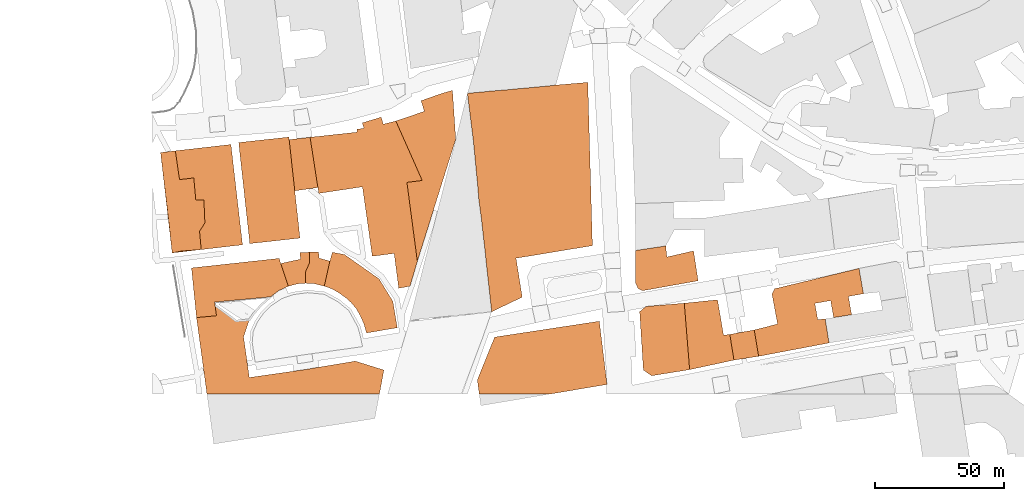
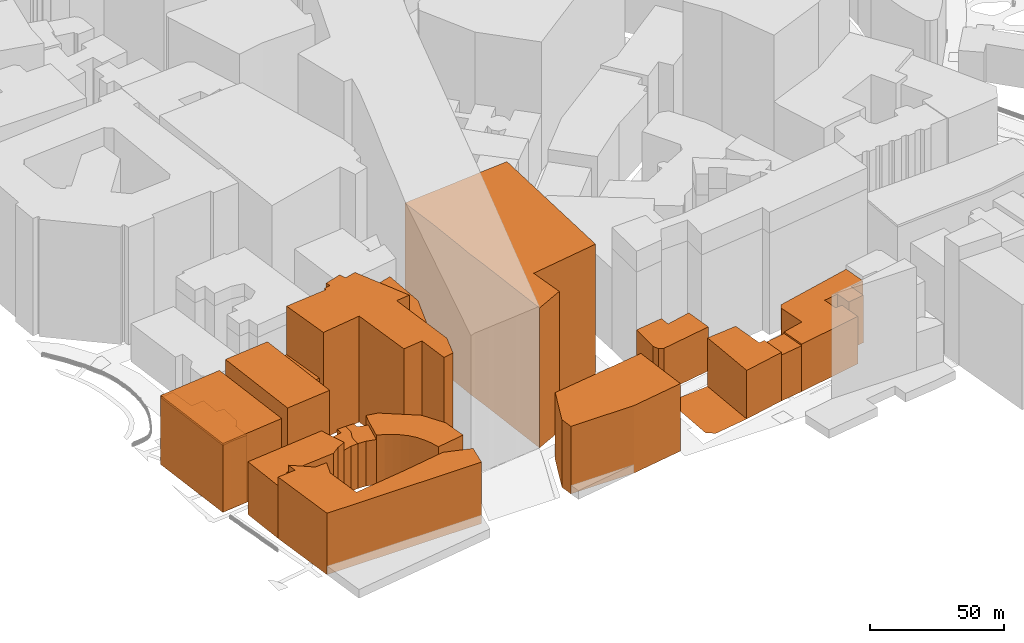
# One storey, part 97 of 200: 18 proxies.
"""IFC4 building model written with IfcOpenShell, lengths in metres."""

from ifc_helpers import new_model, si_unit, origin_with_axes, place, context, subcontext, project, spatial, triangles, material, element, save


model = new_model("IFC4")

# Units and contexts
model_context = context("Model", 3, precision=1e-05, world=origin_with_axes())
body_context = subcontext(model_context, "Body", "Model", "MODEL_VIEW")
ifc_project = project(units=[si_unit("VOLUMEUNIT", "CUBIC_METRE"), si_unit("LENGTHUNIT", "METRE"), si_unit("AREAUNIT", "SQUARE_METRE")], contexts=[model_context])

# Site, building, storey
site_placement = place(None, origin_with_axes())
site = spatial("IfcSite", under=ifc_project, at=site_placement)
building_placement = place(site_placement, origin_with_axes())
building = spatial("IfcBuilding", under=site, at=building_placement, Name="Building")
storey_placement = place(building_placement, origin_with_axes())
storey = spatial("IfcBuildingStorey", under=building, at=storey_placement, Name="Ground")

# Proxies
ifc_material_1 = material()
proxy_1_placement = place(storey_placement, origin_with_axes())
element("IfcBuildingElementProxy", 1, at=proxy_1_placement, inside=storey, material=ifc_material_1, Name="cw_buildings_UK 547", context=body_context, shape_type="Tessellation", body=[
    triangles([(79.1416804523529, -796.2725829939203, 48.42900085449219), (93.49732833597616, -843.2420778598312, 48.42900085449219), (89.3392958956664, -793.206314460359, 48.42900085449219), (81.8362656837595, -794.7394297336651, 48.42900085449219), (81.23231118215404, -817.4343905106749, 48.42900085449219), (98.44516642570602, -815.7154430830286, 48.42900085449219), (88.43336414325819, -790.4652521968928, 48.42900085449219), (60.953187405040644, -798.2470686272588, 48.42900085449219), (99.65307542891698, -855.9019883416261, 48.42900085449219), (104.36862332572166, -814.972114465668, 48.42900085449219), (81.16262412427648, -792.6720280231566, 48.42900085449219), (79.07199339447534, -795.1575520809305, 48.42900085449219), (64.3214141959303, -819.9896206198009, 48.42900085449219), (85.04188933960152, -844.333860760054, 48.42900085449219), (95.26275279568203, -856.7382710231058, 48.42900085449219), (102.48705376955319, -846.3315564192106, 48.42900085449219), (94.14775986964115, -791.951947418563, 48.42900085449219), (104.36862332572166, -814.972114465668, 0.0), (94.14775986964115, -791.951947418563, 0.0), (98.44516642570602, -815.7154430830286, 0.0), (102.48705376955319, -846.3315564192106, 0.0), (99.65307542891698, -855.9019883416261, 0.0), (95.26275279568203, -856.7382710231058, 0.0), (93.49732833597616, -843.2420778598312, 0.0), (85.04188933960152, -844.333860760054, 0.0), (81.23231118215404, -817.4343905106749, 0.0), (64.3214141959303, -819.9896206198009, 0.0), (60.953187405040644, -798.2470686272588, 0.0), (79.1416804523529, -796.2725829939203, 0.0), (79.07199339447534, -795.1575520809305, 0.0), (81.8362656837595, -794.7394297336651, 0.0), (81.16262412427648, -792.6720280231566, 0.0), (88.43336414325819, -790.4652521968928, 0.0), (89.3392958956664, -793.206314460359, 0.0)], [[1, 2, 3], [3, 4, 1], [1, 5, 2], [2, 6, 3], [3, 7, 4], [1, 8, 5], [2, 9, 6], [6, 10, 3], [7, 11, 4], [4, 12, 1], [8, 13, 5], [5, 14, 2], [2, 15, 9], [9, 16, 6], [10, 17, 3], [18, 19, 17], [18, 17, 10], [20, 18, 10], [20, 10, 6], [21, 20, 6], [21, 6, 16], [22, 21, 16], [22, 16, 9], [23, 22, 9], [23, 9, 15], [24, 23, 15], [24, 15, 2], [25, 24, 2], [25, 2, 14], [26, 25, 14], [26, 14, 5], [27, 26, 5], [27, 5, 13], [28, 27, 13], [28, 13, 8], [29, 28, 8], [29, 8, 1], [30, 29, 1], [30, 1, 12], [31, 30, 12], [31, 12, 4], [32, 31, 4], [32, 4, 11], [33, 32, 11], [33, 11, 7], [34, 33, 7], [34, 7, 3], [19, 34, 3], [19, 3, 17], [34, 19, 18], [20, 21, 22], [22, 23, 24], [24, 25, 26], [26, 27, 28], [29, 30, 31], [31, 32, 33], [34, 18, 20], [20, 22, 24], [26, 28, 29], [31, 33, 34], [34, 20, 24], [24, 26, 29], [29, 31, 34], [34, 24, 29]], closed=False),
])
proxy_2_placement = place(storey_placement, origin_with_axes())
element("IfcBuildingElementProxy", 2, at=proxy_2_placement, inside=storey, material=ifc_material_1, Name="cw_buildings_UK 548", context=body_context, shape_type="Tessellation", body=[
    triangles([(43.94939333512132, -799.1297713603745, 35.02800369262695), (37.60781408784035, -839.4324807089092, 35.02800369262695), (52.8461836980538, -799.1762293989597, 35.02800369262695), (52.753267620883726, -798.1773625759068, 35.02800369262695), (33.31040753177548, -800.3144703377675, 35.02800369262695), (57.05067417694859, -837.2954109339975, 35.02800369262695), (33.31040753177548, -800.3144703377675, 0.0), (37.60781408784035, -839.4324807089092, 0.0), (43.94939333512132, -799.1297713603745, 0.0), (52.753267620883726, -798.1773625759068, 0.0), (52.8461836980538, -799.1762293989597, 0.0), (57.05067417694859, -837.2954109339975, 0.0)], [[1, 2, 3], [3, 4, 1], [1, 5, 2], [2, 6, 3], [7, 8, 2], [7, 2, 5], [9, 7, 5], [9, 5, 1], [10, 9, 1], [10, 1, 4], [11, 10, 4], [11, 4, 3], [12, 11, 3], [12, 3, 6], [8, 12, 6], [8, 6, 2], [11, 12, 8], [8, 7, 9], [9, 10, 11], [11, 8, 9]], closed=False),
])
proxy_3_placement = place(storey_placement, origin_with_axes())
element("IfcBuildingElementProxy", 3, at=proxy_3_placement, inside=storey, material=ifc_material_1, Name="cw_buildings_UK 549", context=body_context, shape_type="Tessellation", body=[
    triangles([(30.313826056091646, -801.0345509423611, 31.518003463745117), (3.0659395107992937, -804.1705255272745, 31.518003463745117), (7.5491877179415505, -843.056245705491, 31.518003463745117), (34.79706476649666, -839.8970610947596, 31.518003463745117), (8.780335237182266, -803.496864974317, 31.518003463745117), (34.79706476649666, -839.8970610947596, 0.0), (30.313826056091646, -801.0345509423611, 0.0), (7.5491877179415505, -843.056245705491, 0.0), (3.0659395107992937, -804.1705255272745, 0.0), (8.780335237182266, -803.496864974317, 0.0)], [[1, 2, 3], [3, 4, 1], [1, 5, 2], [6, 7, 1], [6, 1, 4], [8, 6, 4], [8, 4, 3], [9, 8, 3], [9, 3, 2], [10, 9, 2], [10, 2, 5], [7, 10, 5], [7, 5, 1], [9, 10, 7], [7, 6, 8], [8, 9, 7]], closed=False),
])
proxy_4_placement = place(storey_placement, origin_with_axes())
element("IfcBuildingElementProxy", 4, at=proxy_4_placement, inside=storey, material=ifc_material_1, Name="cw_buildings_UK 550", context=body_context, shape_type="Tessellation", body=[
    triangles([(3.0659395107992937, -804.1705255272745, 30.600004196166992), (11.265859294956217, -842.2896690753635, 30.600004196166992), (20.23234621250349, -831.4184120725669, 30.600004196166992), (10.406376084395795, -814.6469081955728, 30.600004196166992), (6.016053451160854, -829.1651782077181, 30.600004196166992), (18.16494450199487, -834.6240167349345, 30.600004196166992), (16.701497293091727, -822.4751446775749, 30.600004196166992), (3.9951097792372705, -812.1845941636168, 30.600004196166992), (7.5491877179415505, -843.056245705491, 30.600004196166992), (18.792128022892868, -841.75542062511, 30.600004196166992), (19.837443387793435, -822.61451879333, 30.600004196166992), (15.93493965643862, -813.9964576684332, 30.600004196166992), (8.780335237182266, -803.496864974317, 30.600004196166992), (15.93493965643862, -813.9964576684332, 0.0), (10.406376084395795, -814.6469081955728, 0.0), (16.701497293091727, -822.4751446775749, 0.0), (19.837443387793435, -822.61451879333, 0.0), (20.23234621250349, -831.4184120725669, 0.0), (18.16494450199487, -834.6240167349345, 0.0), (18.792128022892868, -841.75542062511, 0.0), (11.265859294956217, -842.2896690753635, 0.0), (7.5491877179415505, -843.056245705491, 0.0), (6.016053451160854, -829.1651782077181, 0.0), (3.9951097792372705, -812.1845941636168, 0.0), (3.0659395107992937, -804.1705255272745, 0.0), (8.780335237182266, -803.496864974317, 0.0)], [[1, 2, 3], [3, 4, 1], [1, 5, 2], [2, 6, 3], [3, 7, 4], [1, 8, 5], [5, 9, 2], [2, 10, 6], [3, 11, 7], [7, 12, 4], [4, 13, 1], [14, 15, 4], [14, 4, 12], [16, 14, 12], [16, 12, 7], [17, 16, 7], [17, 7, 11], [18, 17, 11], [18, 11, 3], [19, 18, 3], [19, 3, 6], [20, 19, 6], [20, 6, 10], [21, 20, 10], [21, 10, 2], [22, 21, 2], [22, 2, 9], [23, 22, 9], [23, 9, 5], [24, 23, 5], [24, 5, 8], [25, 24, 8], [25, 8, 1], [26, 25, 1], [26, 1, 13], [15, 26, 13], [15, 13, 4], [25, 26, 15], [15, 14, 16], [16, 17, 18], [19, 20, 21], [21, 22, 23], [23, 24, 25], [15, 16, 18], [18, 19, 21], [21, 23, 25], [25, 15, 18], [18, 21, 25]], closed=False),
])
proxy_5_placement = place(storey_placement, origin_with_axes())
element("IfcBuildingElementProxy", 5, at=proxy_5_placement, inside=storey, material=ifc_material_1, Name="cw_buildings_UK 572", context=body_context, shape_type="Tessellation", body=[
    triangles([(140.69913238828664, -845.1003994032326, 63.96000289916992), (137.2147415074599, -779.8727434256065, 63.96000289916992), (129.36327600616525, -780.5463659916151, 63.96000289916992), (127.31910331494915, -830.1175490052369, 63.96000289916992), (152.4995881497329, -778.4557542552884, 63.96000289916992), (124.34575085855782, -801.4526732896264, 63.96000289916992), (128.87544760754787, -844.0086544899588, 63.96000289916992), (168.4812863773069, -776.9923070463852, 63.96000289916992), (144.13706523052832, -779.222330885416, 63.96000289916992), (124.11346066563264, -799.1297713603745, 63.96000289916992), (125.80919806746097, -816.6678518674963, 63.96000289916992), (131.26807458162625, -865.8208745469038, 63.96000289916992), (170.2699398563053, -840.2222673648548, 63.96000289916992), (156.10010513354771, -778.0376319080231, 63.96000289916992), (150.57156055497936, -778.6183763838105, 63.96000289916992), (139.67705553941582, -779.6172052199144, 63.96000289916992), (130.7105591251313, -780.3837818500419, 63.96000289916992), (121.86022680078388, -781.2432745573395, 63.96000289916992), (126.27377845331134, -822.3822286004048, 63.96000289916992), (127.62108056575188, -832.905069307288, 63.96000289916992), (129.1774438518251, -847.0748850365712, 63.96000289916992), (143.09174036889053, -860.1529558525804, 63.96000289916992), (129.1774438518251, -847.0748850365712, 0.0), (131.26807458162625, -865.8208745469038, 0.0), (128.87544760754787, -844.0086544899588, 0.0), (127.62108056575188, -832.905069307288, 0.0), (127.31910331494915, -830.1175490052369, 0.0), (126.27377845331134, -822.3822286004048, 0.0), (125.80919806746097, -816.6678518674963, 0.0), (124.34575085855782, -801.4526732896264, 0.0), (124.11346066563264, -799.1297713603745, 0.0), (121.86022680078388, -781.2432745573395, 0.0), (129.36327600616525, -780.5463659916151, 0.0), (130.7105591251313, -780.3837818500419, 0.0), (137.2147415074599, -779.8727434256065, 0.0), (139.67705553941582, -779.6172052199144, 0.0), (144.13706523052832, -779.222330885416, 0.0), (150.57156055497936, -778.6183763838105, 0.0), (152.4995881497329, -778.4557542552884, 0.0), (156.10010513354771, -778.0376319080231, 0.0), (168.4812863773069, -776.9923070463852, 0.0), (170.2699398563053, -840.2222673648548, 0.0), (140.69913238828664, -845.1003994032326, 0.0), (143.09174036889053, -860.1529558525804, 0.0)], [[1, 2, 3], [3, 4, 1], [1, 5, 2], [3, 6, 4], [4, 7, 1], [1, 8, 5], [5, 9, 2], [3, 10, 6], [6, 11, 4], [7, 12, 1], [1, 13, 8], [8, 14, 5], [5, 15, 9], [9, 16, 2], [2, 17, 3], [3, 18, 10], [11, 19, 4], [4, 20, 7], [7, 21, 12], [12, 22, 1], [23, 24, 12], [23, 12, 21], [25, 23, 21], [25, 21, 7], [26, 25, 7], [26, 7, 20], [27, 26, 20], [27, 20, 4], [28, 27, 4], [28, 4, 19], [29, 28, 19], [29, 19, 11], [30, 29, 11], [30, 11, 6], [31, 30, 6], [31, 6, 10], [32, 31, 10], [32, 10, 18], [33, 32, 18], [33, 18, 3], [34, 33, 3], [34, 3, 17], [35, 34, 17], [35, 17, 2], [36, 35, 2], [36, 2, 16], [37, 36, 16], [37, 16, 9], [38, 37, 9], [38, 9, 15], [39, 38, 15], [39, 15, 5], [40, 39, 5], [40, 5, 14], [41, 40, 14], [41, 14, 8], [42, 41, 8], [42, 8, 13], [43, 42, 13], [43, 13, 1], [44, 43, 1], [44, 1, 22], [24, 44, 22], [24, 22, 12], [43, 44, 24], [24, 23, 25], [25, 26, 27], [27, 28, 29], [31, 32, 33], [33, 34, 35], [35, 36, 37], [37, 38, 39], [39, 40, 41], [41, 42, 43], [43, 24, 25], [27, 29, 30], [30, 31, 33], [35, 37, 39], [39, 41, 43], [43, 25, 27], [27, 30, 33], [35, 39, 43], [43, 27, 33], [33, 35, 43]], closed=False),
])
proxy_6_placement = place(storey_placement, origin_with_axes())
element("IfcBuildingElementProxy", 6, at=proxy_6_placement, inside=storey, material=ifc_material_1, Name="cw_buildings_UK 578", context=body_context, shape_type="Tessellation", body=[
    triangles([(58.69995354019188, -798.5258168587691, 26.31700325012207), (52.8461836980538, -799.1762293989597, 26.31700325012207), (63.97297890654252, -817.7363867549522, 26.31700325012207), (60.953187405040644, -798.2470686272588, 26.31700325012207), (55.02973050502501, -818.9907537967482, 26.31700325012207), (58.69995354019188, -798.5258168587691, 0.0), (52.8461836980538, -799.1762293989597, 0.0), (60.953187405040644, -798.2470686272588, 0.0), (63.97297890654252, -817.7363867549522, 0.0), (55.02973050502501, -818.9907537967482, 0.0)], [[1, 2, 3], [3, 4, 1], [2, 5, 3], [6, 7, 2], [6, 2, 1], [8, 6, 1], [8, 1, 4], [9, 8, 4], [9, 4, 3], [10, 9, 3], [10, 3, 5], [7, 10, 5], [7, 5, 2], [9, 10, 7], [6, 8, 9], [9, 7, 6]], closed=False),
])
proxy_7_placement = place(storey_placement, origin_with_axes())
element("IfcBuildingElementProxy", 7, at=proxy_7_placement, inside=storey, material=ifc_material_1, Name="cw_buildings_UK 581", context=body_context, shape_type="Tessellation", body=[
    triangles([(112.10394373055374, -781.2200265445725, 31.624000549316406), (104.36862332572166, -814.972114465668, 31.624000549316406), (102.48705376955319, -846.3315564192106, 31.624000549316406), (117.35375907108634, -799.0136072704375, 31.624000549316406), (105.20486802025232, -788.2120183320441, 31.624000549316406), (98.44516642570602, -815.7154430830286, 31.624000549316406), (116.09937303581586, -780.1050336185317, 31.624000549316406), (103.9040239463968, -784.1004629237938, 31.624000549316406), (94.14775986964115, -791.951947418563, 31.624000549316406), (105.20486802025232, -788.2120183320441, 0.0), (94.14775986964115, -791.951947418563, 0.0), (103.9040239463968, -784.1004629237938, 0.0), (112.10394373055374, -781.2200265445725, 0.0), (116.09937303581586, -780.1050336185317, 0.0), (117.35375907108634, -799.0136072704375, 0.0), (102.48705376955319, -846.3315564192106, 0.0), (98.44516642570602, -815.7154430830286, 0.0), (104.36862332572166, -814.972114465668, 0.0)], [[1, 2, 3], [3, 4, 1], [1, 5, 2], [2, 6, 3], [4, 7, 1], [1, 8, 5], [5, 9, 2], [10, 11, 9], [10, 9, 5], [12, 10, 5], [12, 5, 8], [13, 12, 8], [13, 8, 1], [14, 13, 1], [14, 1, 7], [15, 14, 7], [15, 7, 4], [16, 15, 4], [16, 4, 3], [17, 16, 3], [17, 3, 6], [18, 17, 6], [18, 6, 2], [11, 18, 2], [11, 2, 9], [18, 11, 10], [10, 12, 13], [13, 14, 15], [16, 17, 18], [18, 10, 13], [13, 15, 16], [16, 18, 13]], closed=False),
])
proxy_8_placement = place(storey_placement, origin_with_axes())
element("IfcBuildingElementProxy", 8, at=proxy_8_placement, inside=storey, material=ifc_material_1, Name="cw_buildings_UK 723", context=body_context, shape_type="Tessellation", body=[
    triangles([(256.39812251481845, -862.5629873064172, 21.71000099182129), (273.49483622318434, -849.0203456012948, 21.71000099182129), (241.9495406363529, -870.5538459169414, 21.71000099182129), (257.48989591830406, -868.8581085151131, 21.71000099182129), (262.50741038208207, -861.4944429222242, 21.71000099182129), (232.91336973994837, -872.8535378203752, 21.71000099182129), (263.64564182415273, -868.0683171107988, 21.71000099182129), (261.8802197386312, -877.894282490538, 21.71000099182129), (269.3832618214596, -859.8683973266419, 21.71000099182129), (239.76599305035248, -858.8695400003264, 21.71000099182129), (234.6323331933388, -883.0744012764558, 21.71000099182129), (260.39354944589627, -868.5793602836029, 21.71000099182129), (270.6144117148846, -866.9533146880208, 21.71000099182129), (275.190568876644, -858.8463109810339, 21.71000099182129), (240.85776682480437, -856.8950543669879, 21.71000099182129), (275.190568876644, -858.8463109810339, 0.0), (273.49483622318434, -849.0203456012948, 0.0), (269.3832618214596, -859.8683973266419, 0.0), (270.6144117148846, -866.9533146880208, 0.0), (263.64564182415273, -868.0683171107988, 0.0), (262.50741038208207, -861.4944429222242, 0.0), (256.39812251481845, -862.5629873064172, 0.0), (257.48989591830406, -868.8581085151131, 0.0), (260.39354944589627, -868.5793602836029, 0.0), (261.8802197386312, -877.894282490538, 0.0), (234.6323331933388, -883.0744012764558, 0.0), (232.91336973994837, -872.8535378203752, 0.0), (241.9495406363529, -870.5538459169414, 0.0), (239.76599305035248, -858.8695400003264, 0.0), (240.85776682480437, -856.8950543669879, 0.0)], [[1, 2, 3], [3, 4, 1], [1, 5, 2], [3, 6, 4], [5, 7, 2], [6, 8, 4], [7, 9, 2], [2, 10, 3], [6, 11, 8], [8, 12, 4], [7, 13, 9], [9, 14, 2], [2, 15, 10], [16, 17, 2], [16, 2, 14], [18, 16, 14], [18, 14, 9], [19, 18, 9], [19, 9, 13], [20, 19, 13], [20, 13, 7], [21, 20, 7], [21, 7, 5], [22, 21, 5], [22, 5, 1], [23, 22, 1], [23, 1, 4], [24, 23, 4], [24, 4, 12], [25, 24, 12], [25, 12, 8], [26, 25, 8], [26, 8, 11], [27, 26, 11], [27, 11, 6], [28, 27, 6], [28, 6, 3], [29, 28, 3], [29, 3, 10], [30, 29, 10], [30, 10, 15], [17, 30, 15], [17, 15, 2], [29, 30, 17], [17, 16, 18], [18, 19, 20], [23, 24, 25], [25, 26, 27], [28, 29, 17], [17, 18, 20], [23, 25, 27], [17, 20, 21], [23, 27, 28], [17, 21, 22], [22, 23, 28], [28, 17, 22]], closed=False),
])
proxy_9_placement = place(storey_placement, origin_with_axes())
element("IfcBuildingElementProxy", 9, at=proxy_9_placement, inside=storey, material=ifc_material_1, Name="cw_buildings_UK 724", context=body_context, shape_type="Tessellation", body=[
    triangles([(223.45907282371212, -874.5725042414961, 20.985002517700195), (228.96440144100166, -883.9338844870161, 20.985002517700195), (234.6323331933388, -883.0744012764558, 20.985002517700195), (227.36158367761988, -873.8523951466908, 20.985002517700195), (225.0618905870939, -884.5378389886216, 20.985002517700195), (232.91336973994837, -872.8535378203752, 20.985002517700195), (228.96440144100166, -883.9338844870161, 0.0), (234.6323331933388, -883.0744012764558, 0.0), (225.0618905870939, -884.5378389886216, 0.0), (223.45907282371212, -874.5725042414961, 0.0), (227.36158367761988, -873.8523951466908, 0.0), (232.91336973994837, -872.8535378203752, 0.0)], [[1, 2, 3], [3, 4, 1], [1, 5, 2], [3, 6, 4], [7, 8, 3], [7, 3, 2], [9, 7, 2], [9, 2, 5], [10, 9, 5], [10, 5, 1], [11, 10, 1], [11, 1, 4], [12, 11, 4], [12, 4, 6], [8, 12, 6], [8, 6, 3], [11, 12, 8], [7, 9, 10], [10, 11, 8], [8, 7, 10]], closed=False),
])
proxy_10_placement = place(storey_placement, origin_with_axes())
element("IfcBuildingElementProxy", 10, at=proxy_10_placement, inside=storey, material=ifc_material_1, Name="cw_buildings_UK 725", context=body_context, shape_type="Tessellation", body=[
    triangles([(205.82808811034187, -862.4933002485396, 22.180999755859375), (225.0618905870939, -884.5378389886216, 22.180999755859375), (221.0200044303389, -874.8977105115913, 22.180999755859375), (218.7203101527208, -861.1692366521288, 22.180999755859375), (207.89548982085049, -888.231291043081, 22.180999755859375), (223.45907282371212, -874.5725042414961, 22.180999755859375), (207.89548982085049, -888.231291043081, 0.0), (225.0618905870939, -884.5378389886216, 0.0), (205.82808811034187, -862.4933002485396, 0.0), (218.7203101527208, -861.1692366521288, 0.0), (221.0200044303389, -874.8977105115913, 0.0), (223.45907282371212, -874.5725042414961, 0.0)], [[1, 2, 3], [3, 4, 1], [1, 5, 2], [2, 6, 3], [7, 8, 2], [7, 2, 5], [9, 7, 5], [9, 5, 1], [10, 9, 1], [10, 1, 4], [11, 10, 4], [11, 4, 3], [12, 11, 3], [12, 3, 6], [8, 12, 6], [8, 6, 2], [11, 12, 8], [8, 7, 9], [9, 10, 11], [11, 8, 9]], closed=False),
])
proxy_11_placement = place(storey_placement, origin_with_axes())
element("IfcBuildingElementProxy", 11, at=proxy_11_placement, inside=storey, material=ifc_material_1, Name="cw_buildings_UK 734", context=body_context, shape_type="Tessellation", body=[
    triangles([(199.0974187069634, -844.6067939487674, 20.088003158569336), (198.65604834693107, -840.332616411995, 20.088003158569336), (187.97062349847468, -856.8485963284029, 20.088003158569336), (211.17662269991985, -853.8288000785324, 20.088003158569336), (186.8556305724338, -854.4792173670915, 20.088003158569336), (189.71281893888803, -857.6616215003783, 20.088003158569336), (209.4344272595065, -842.2374102390874, 20.088003158569336), (186.9717566754219, -842.0748071040398, 20.088003158569336), (199.0974187069634, -844.6067939487674, 0.0), (198.65604834693107, -840.332616411995, 0.0), (209.4344272595065, -842.2374102390874, 0.0), (211.17662269991985, -853.8288000785324, 0.0), (189.71281893888803, -857.6616215003783, 0.0), (187.97062349847468, -856.8485963284029, 0.0), (186.8556305724338, -854.4792173670915, 0.0), (186.9717566754219, -842.0748071040398, 0.0)], [[1, 2, 3], [3, 4, 1], [2, 5, 3], [3, 6, 4], [4, 7, 1], [2, 8, 5], [9, 10, 2], [9, 2, 1], [11, 9, 1], [11, 1, 7], [12, 11, 7], [12, 7, 4], [13, 12, 4], [13, 4, 6], [14, 13, 6], [14, 6, 3], [15, 14, 3], [15, 3, 5], [16, 15, 5], [16, 5, 8], [10, 16, 8], [10, 8, 2], [15, 16, 10], [9, 11, 12], [12, 13, 14], [14, 15, 10], [9, 12, 14], [14, 10, 9]], closed=False),
])
proxy_12_placement = place(storey_placement, origin_with_axes())
element("IfcBuildingElementProxy", 12, at=proxy_12_placement, inside=storey, material=ifc_material_1, Name="cw_buildings_UK 735", context=body_context, shape_type="Tessellation", body=[
    triangles([(78.90937126595323, -864.7465341133884, 22.466001510620117), (80.39604749414889, -867.3714417836547, 22.466001510620117), (68.61883974546964, -846.209610525057, 22.466001510620117), (76.86519857473712, -862.2610100556144, 22.466001510620117), (93.00951893083327, -861.773195902103, 22.466001510620117), (74.49581961342577, -860.1703793258133, 22.466001510620117), (81.8362656837595, -870.6467619941116, 22.466001510620117), (71.96383751706678, -858.4281838853999, 22.466001510620117), (82.78865547475276, -874.0382273010309, 22.466001510620117), (74.26352942050059, -843.6543946610369, 22.466001510620117), (69.36216836283023, -856.9415171539415, 22.466001510620117), (94.70525633266159, -872.0172836291074, 22.466001510620117), (87.62034846802004, -853.0390039258494, 22.466001510620117), (69.57122953646291, -842.7716824311839, 22.466001510620117), (66.45850296431647, -855.896201789041, 22.466001510620117), (68.61883974546964, -846.209610525057, 0.0), (66.45850296431647, -855.896201789041, 0.0), (69.57122953646291, -842.7716824311839, 0.0), (74.26352942050059, -843.6543946610369, 0.0), (87.62034846802004, -853.0390039258494, 0.0), (93.00951893083327, -861.773195902103, 0.0), (94.70525633266159, -872.0172836291074, 0.0), (82.78865547475276, -874.0382273010309, 0.0), (81.8362656837595, -870.6467619941116, 0.0), (80.39604749414889, -867.3714417836547, 0.0), (78.90937126595323, -864.7465341133884, 0.0), (76.86519857473712, -862.2610100556144, 0.0), (74.49581961342577, -860.1703793258133, 0.0), (71.96383751706678, -858.4281838853999, 0.0), (69.36216836283023, -856.9415171539415, 0.0)], [[1, 2, 3], [3, 4, 1], [2, 5, 3], [3, 6, 4], [2, 7, 5], [3, 8, 6], [7, 9, 5], [5, 10, 3], [3, 11, 8], [9, 12, 5], [5, 13, 10], [10, 14, 3], [3, 15, 11], [16, 17, 15], [16, 15, 3], [18, 16, 3], [18, 3, 14], [19, 18, 14], [19, 14, 10], [20, 19, 10], [20, 10, 13], [21, 20, 13], [21, 13, 5], [22, 21, 5], [22, 5, 12], [23, 22, 12], [23, 12, 9], [24, 23, 9], [24, 9, 7], [25, 24, 7], [25, 7, 2], [26, 25, 2], [26, 2, 1], [27, 26, 1], [27, 1, 4], [28, 27, 4], [28, 4, 6], [29, 28, 6], [29, 6, 8], [30, 29, 8], [30, 8, 11], [17, 30, 11], [17, 11, 15], [30, 17, 16], [16, 18, 19], [19, 20, 21], [21, 22, 23], [29, 30, 16], [16, 19, 21], [21, 23, 24], [28, 29, 16], [21, 24, 25], [27, 28, 16], [16, 21, 25], [26, 27, 16], [16, 25, 26]], closed=False),
])
proxy_13_placement = place(storey_placement, origin_with_axes())
element("IfcBuildingElementProxy", 13, at=proxy_13_placement, inside=storey, material=ifc_material_1, Name="cw_buildings_UK 736", context=body_context, shape_type="Tessellation", body=[
    triangles([(23.995475828103192, -862.0984021721982, 24.095001220703125), (48.80429635420663, -857.6616215003783, 24.095001220703125), (15.028998407293162, -848.8345134469547, 24.095001220703125), (16.98025502133919, -868.0683171107988, 24.095001220703125), (31.033944647634197, -861.4247558643466, 24.095001220703125), (49.57085399085974, -847.138780793495, 24.095001220703125), (24.715594419645747, -867.3482080159936, 24.095001220703125), (45.62190171765713, -860.0542342293508, 24.095001220703125), (52.54420644725106, -855.942659827626, 24.095001220703125), (49.0133575278393, -845.1410661408639, 24.095001220703125), (49.57085399085974, -847.138780793495, 0.0), (49.0133575278393, -845.1410661408639, 0.0), (52.54420644725106, -855.942659827626, 0.0), (48.80429635420663, -857.6616215003783, 0.0), (45.62190171765713, -860.0542342293508, 0.0), (31.033944647634197, -861.4247558643466, 0.0), (23.995475828103192, -862.0984021721982, 0.0), (24.715594419645747, -867.3482080159936, 0.0), (16.98025502133919, -868.0683171107988, 0.0), (15.028998407293162, -848.8345134469547, 0.0)], [[1, 2, 3], [3, 4, 1], [1, 5, 2], [2, 6, 3], [4, 7, 1], [5, 8, 2], [2, 9, 6], [6, 10, 3], [11, 12, 10], [11, 10, 6], [13, 11, 6], [13, 6, 9], [14, 13, 9], [14, 9, 2], [15, 14, 2], [15, 2, 8], [16, 15, 8], [16, 8, 5], [17, 16, 5], [17, 5, 1], [18, 17, 1], [18, 1, 7], [19, 18, 7], [19, 7, 4], [20, 19, 4], [20, 4, 3], [12, 20, 3], [12, 3, 10], [20, 12, 11], [11, 13, 14], [14, 15, 16], [17, 18, 19], [20, 11, 14], [14, 16, 17], [17, 19, 20], [20, 14, 17]], closed=False),
])
proxy_14_placement = place(storey_placement, origin_with_axes())
element("IfcBuildingElementProxy", 14, at=proxy_14_placement, inside=storey, material=ifc_material_1, Name="cw_buildings_UK 737", context=body_context, shape_type="Tessellation", body=[
    triangles([(60.79058426999302, -846.7438827171535, 20.53000259399414), (62.5560087296989, -854.920573482018, 20.53000259399414), (64.39112024728233, -845.0249210444014, 20.53000259399414), (64.27495615734526, -842.7019953733064, 20.53000259399414), (59.21099196462728, -850.2979559074892, 20.53000259399414), (66.45850296431647, -855.896201789041, 20.53000259399414), (60.72089721211546, -842.7484534118914, 20.53000259399414), (59.14130490674973, -854.7579655986017, 20.53000259399414), (68.61883974546964, -846.209610525057, 20.53000259399414), (66.45850296431647, -855.896201789041, 0.0), (68.61883974546964, -846.209610525057, 0.0), (62.5560087296989, -854.920573482018, 0.0), (59.14130490674973, -854.7579655986017, 0.0), (59.21099196462728, -850.2979559074892, 0.0), (60.79058426999302, -846.7438827171535, 0.0), (60.72089721211546, -842.7484534118914, 0.0), (64.27495615734526, -842.7019953733064, 0.0), (64.39112024728233, -845.0249210444014, 0.0)], [[1, 2, 3], [3, 4, 1], [1, 5, 2], [2, 6, 3], [4, 7, 1], [5, 8, 2], [6, 9, 3], [10, 11, 9], [10, 9, 6], [12, 10, 6], [12, 6, 2], [13, 12, 2], [13, 2, 8], [14, 13, 8], [14, 8, 5], [15, 14, 5], [15, 5, 1], [16, 15, 1], [16, 1, 7], [17, 16, 7], [17, 7, 4], [18, 17, 4], [18, 4, 3], [11, 18, 3], [11, 3, 9], [18, 11, 10], [12, 13, 14], [15, 16, 17], [18, 10, 12], [12, 14, 15], [15, 17, 18], [18, 12, 15]], closed=False),
])
proxy_15_placement = place(storey_placement, origin_with_axes())
element("IfcBuildingElementProxy", 15, at=proxy_15_placement, inside=storey, material=ifc_material_1, Name="cw_buildings_UK 738", context=body_context, shape_type="Tessellation", body=[
    triangles([(59.21099196462728, -850.2979559074892, 20.570003509521484), (57.23650633128874, -845.4430481400352, 20.570003509521484), (49.57085399085974, -847.138780793495, 20.570003509521484), (56.00534931531078, -855.013489559188, 20.570003509521484), (60.72089721211546, -842.7484534118914, 20.570003509521484), (52.54420644725106, -855.942659827626, 20.570003509521484), (59.14130490674973, -854.7579655986017, 20.570003509521484), (60.79058426999302, -846.7438827171535, 20.570003509521484), (57.027445157656075, -842.9110612953077, 20.570003509521484), (60.79058426999302, -846.7438827171535, 0.0), (60.72089721211546, -842.7484534118914, 0.0), (59.21099196462728, -850.2979559074892, 0.0), (59.14130490674973, -854.7579655986017, 0.0), (56.00534931531078, -855.013489559188, 0.0), (52.54420644725106, -855.942659827626, 0.0), (49.57085399085974, -847.138780793495, 0.0), (57.23650633128874, -845.4430481400352, 0.0), (57.027445157656075, -842.9110612953077, 0.0)], [[1, 2, 3], [3, 4, 1], [1, 5, 2], [3, 6, 4], [4, 7, 1], [1, 8, 5], [5, 9, 2], [10, 11, 5], [10, 5, 8], [12, 10, 8], [12, 8, 1], [13, 12, 1], [13, 1, 7], [14, 13, 7], [14, 7, 4], [15, 14, 4], [15, 4, 6], [16, 15, 6], [16, 6, 3], [17, 16, 3], [17, 3, 2], [18, 17, 2], [18, 2, 9], [11, 18, 9], [11, 9, 5], [17, 18, 11], [11, 10, 12], [12, 13, 14], [14, 15, 16], [17, 11, 12], [12, 14, 16], [16, 17, 12]], closed=False),
])
proxy_16_placement = place(storey_placement, origin_with_axes())
element("IfcBuildingElementProxy", 16, at=proxy_16_placement, inside=storey, material=ifc_material_1, Name="cw_buildings_UK 838", context=body_context, shape_type="Tessellation", body=[
    triangles([(172.9412960684194, -869.4620725134558, 30.847999572753906), (132.40629652695964, -875.6178196063967, 30.847999572753906), (125.69305297099838, -892.2034913290506, 30.847999572753906), (175.91464852481073, -893.9689062920193, 0.0), (172.9412960684194, -869.4620725134558, 0.0), (175.91464852481073, -893.9689062920193, 30.847999572753906), (132.40629652695964, -875.6178196063967, 0.0), (125.69305297099838, -892.2034913290506, 0.0), (126.44626789833444, -897.6930708238181, 30.847999572753906), (133.36980708439702, -897.6930708238181, 30.847999572753906), (153.79058430748393, -897.6930708238181, 16.877314056567783), (126.44626789833444, -897.6930708238181, 16.9536431732578), (153.79058430748393, -897.6930708238181, 0.0), (133.36980708439702, -897.6930708238181, 0.0), (153.79058430748393, -897.6930708238181, 30.847999572753906), (126.44626789833444, -897.6930708238181, 0.0)], [[1, 2, 3], [4, 5, 1], [4, 1, 6], [7, 8, 3], [7, 3, 2], [5, 7, 2], [5, 2, 1], [8, 7, 5], [1, 3, 9], [6, 1, 10], [4, 6, 11], [3, 8, 12], [5, 4, 13], [8, 5, 14], [9, 10, 1], [10, 15, 6], [11, 13, 4], [12, 9, 3], [13, 14, 5], [14, 16, 8], [6, 15, 11], [8, 16, 12], [12, 16, 14], [14, 13, 11], [11, 15, 10], [10, 9, 12], [12, 14, 11], [11, 10, 12]], closed=False),
])
proxy_17_placement = place(storey_placement, origin_with_axes())
element("IfcBuildingElementProxy", 17, at=proxy_17_placement, inside=storey, material=ifc_material_1, Name="cw_buildings_UK 839", context=body_context, shape_type="Tessellation", body=[
    triangles([(35.215206107236476, -875.5249035292265, 28.071002960205078), (32.24185365084515, -869.3691564362857, 28.071002960205078), (30.058306843873943, -867.650190015165, 28.071002960205078), (89.54837606277354, -888.3706651588361, 28.071002960205078), (59.55942725401506, -888.0919169273259, 28.071002960205078), (37.421981933500206, -891.2510920413201, 28.071002960205078), (37.398752914207684, -868.9974826308683, 28.071002960205078), (24.15807896315082, -863.2830964012225, 28.071002960205078), (24.715594419645747, -867.3482080159936, 28.071002960205078), (78.42156186081034, -884.9095127940392, 28.071002960205078), (24.715594419645747, -867.3482080159936, 0.0), (16.98025502133919, -868.0683171107988, 0.0), (16.98025502133919, -868.0683171107988, 28.071002960205078), (24.15807896315082, -863.2830964012225, 0.0), (30.058306843873943, -867.650190015165, 0.0), (32.24185365084515, -869.3691564362857, 0.0), (37.398752914207684, -868.9974826308683, 0.0), (35.215206107236476, -875.5249035292265, 0.0), (37.421981933500206, -891.2510920413201, 0.0), (59.55942725401506, -888.0919169273259, 0.0), (78.42156186081034, -884.9095127940392, 0.0), (89.54837606277354, -888.3706651588361, 0.0), (29.037389897119077, -897.6930708238181, 28.071002960205078), (26.158102772702016, -897.6930708238181, 28.071002960205078), (33.98045353578472, -897.6930708238181, 28.071002960205078), (24.06301104976789, -897.6930708238181, 28.071002960205078), (21.01360431364834, -897.6930708238181, 28.071002960205078), (87.80834430042026, -897.6930708238181, 14.145766434374694), (21.01360431364834, -897.6930708238181, 16.982721227322457), (24.06301104976789, -897.6930708238181, 0.0), (26.158102772702016, -897.6930708238181, 0.0), (68.11590263246482, -897.6930708238181, 0.0), (29.037389897119077, -897.6930708238181, 0.0), (33.98045353578472, -897.6930708238181, 0.0), (68.11590263246484, -897.6930708238181, 28.071002960205078), (87.80834430042026, -897.6930708238181, 0.0), (21.01360431364834, -897.6930708238181, 0.0), (78.5160531141334, -897.6930708238181, 28.071002960205078), (87.80834430042026, -897.6930708238181, 28.071002960205078), (78.5160531141334, -897.6930708238181, 0.0)], [[1, 2, 3], [4, 5, 6], [1, 7, 2], [3, 8, 9], [4, 10, 5], [11, 12, 13], [11, 13, 9], [14, 11, 9], [14, 9, 8], [15, 14, 8], [15, 8, 3], [16, 15, 3], [16, 3, 2], [17, 16, 2], [17, 2, 7], [18, 17, 7], [18, 7, 1], [19, 18, 1], [19, 1, 6], [20, 19, 6], [20, 6, 5], [21, 20, 5], [21, 5, 10], [22, 21, 10], [22, 10, 4], [20, 21, 22], [11, 14, 15], [16, 17, 18], [19, 20, 22], [15, 16, 18], [6, 1, 23], [1, 3, 24], [4, 6, 25], [3, 9, 26], [9, 13, 27], [22, 4, 28], [13, 12, 29], [12, 11, 30], [11, 15, 31], [19, 22, 32], [15, 18, 33], [18, 19, 34], [23, 25, 6], [24, 23, 1], [25, 35, 4], [26, 24, 3], [27, 26, 9], [28, 36, 22], [29, 27, 13], [30, 37, 12], [31, 30, 11], [32, 34, 19], [33, 31, 15], [34, 33, 18], [4, 35, 38], [4, 38, 39], [4, 39, 28], [12, 37, 29], [22, 36, 40], [22, 40, 32], [40, 36, 28], [28, 39, 38], [26, 27, 29], [29, 37, 30], [32, 40, 28], [28, 38, 35], [24, 26, 29], [29, 30, 31], [34, 32, 28], [28, 35, 25], [23, 24, 29], [29, 31, 33], [33, 34, 28], [28, 25, 23], [23, 29, 33], [33, 28, 23]], closed=False),
])
ifc_material_2 = material(Name="buildingConstruction")
proxy_18_placement = place(storey_placement, origin_with_axes())
element("IfcBuildingElementProxy", 18, at=proxy_18_placement, inside=storey, material=ifc_material_2, Name="cw_surface_buildingConstruction_4", ObjectType="Building Construction", context=body_context, shape_type="Tessellation", body=[
    triangles([(193.17396180694774, -890.6006700043924, 0.0), (205.83391027569166, -862.4933002485396, 0.0), (188.55132998731315, -865.8150832459501, 0.0), (189.99156717039824, -888.3938941781287, 0.0), (207.90131198620028, -888.231291043081, 0.0), (190.943975954866, -863.7476815354415, 0.0)], [[1, 2, 3], [3, 4, 1], [1, 5, 2], [2, 6, 3]], closed=True),
])

save(model, "model.ifc")
